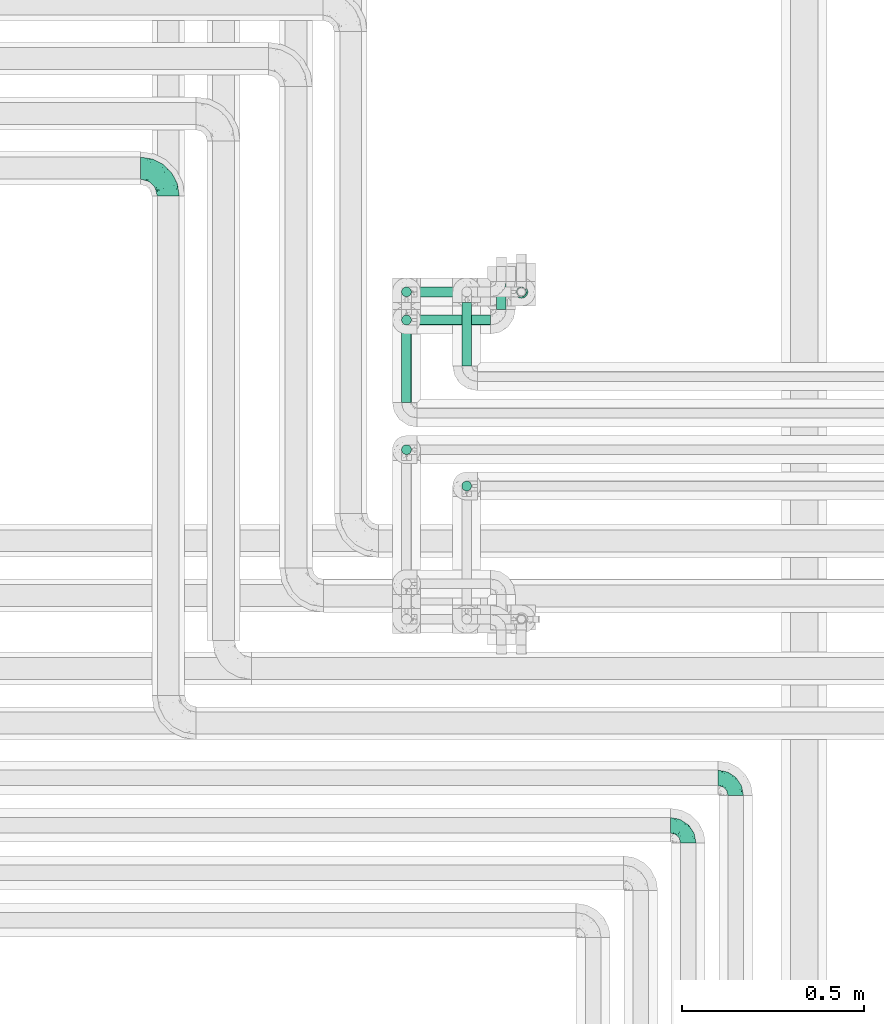
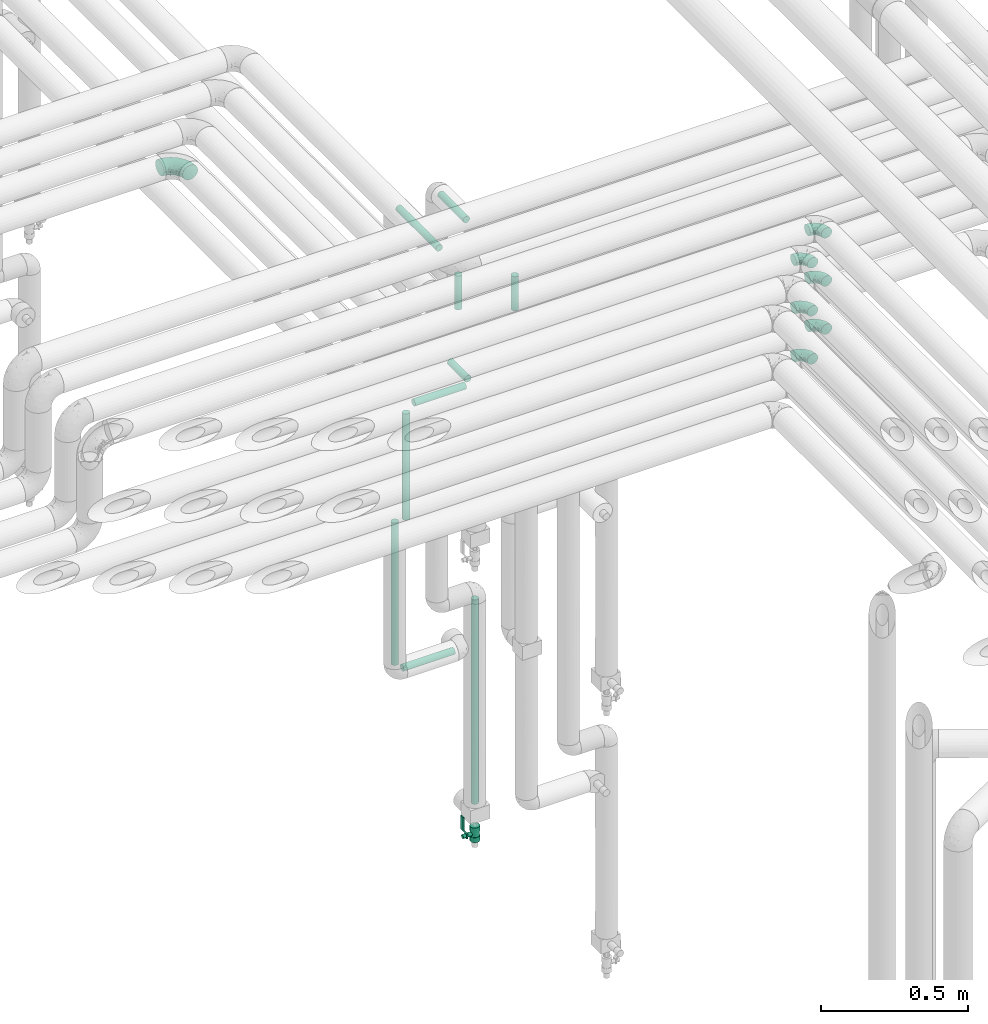
# One storey, part 635 of 824: 10 flow segments, 7 flow fittings, 1 flow controller.
"""IFC2X3 building model written with IfcOpenShell, lengths in millimetres."""

from ifc_helpers import new_model, entity, si_unit, converted_unit, derived_unit, direction, frame, origin, origin_2d_with_axis, place, context, subcontext, project, spatial, polyline, circle, outline, extrude, faceted_brep, source, transform, mapped, material, material_list, type_object, type_shapes, element, save


model = new_model("IFC2X3")

# Units and contexts
model_context = context("Model", 3, precision=0.01, world=origin(), true_north=direction((6.12303176911189e-17, 1.0)))
body_context = subcontext(model_context, "Body", "Model", "MODEL_VIEW")
ifc_project = project(units=[si_unit("LENGTHUNIT", "METRE", prefix="MILLI"), si_unit("AREAUNIT", "SQUARE_METRE"), si_unit("VOLUMEUNIT", "CUBIC_METRE"), converted_unit("PLANEANGLEUNIT", "DEGREE", entity("IfcRatioMeasure", 0.0174532925199433), si_unit("PLANEANGLEUNIT", "RADIAN"), dimensions=[0, 0, 0, 0, 0, 0, 0]), si_unit("MASSUNIT", "GRAM", prefix="KILO"), derived_unit("MASSDENSITYUNIT", [(si_unit("MASSUNIT", "GRAM", prefix="KILO"), 1), (si_unit("LENGTHUNIT", "METRE"), -3)]), derived_unit("MOMENTOFINERTIAUNIT", [(si_unit("LENGTHUNIT", "METRE"), 4)]), si_unit("TIMEUNIT", "SECOND"), si_unit("FREQUENCYUNIT", "HERTZ"), si_unit("THERMODYNAMICTEMPERATUREUNIT", "DEGREE_CELSIUS"), derived_unit("THERMALTRANSMITTANCEUNIT", [(si_unit("MASSUNIT", "GRAM", prefix="KILO"), 1), (si_unit("THERMODYNAMICTEMPERATUREUNIT", "KELVIN"), -1), (si_unit("TIMEUNIT", "SECOND"), -3)]), derived_unit("VOLUMETRICFLOWRATEUNIT", [(si_unit("LENGTHUNIT", "METRE"), 3), (si_unit("TIMEUNIT", "SECOND"), -1)]), derived_unit("MASSFLOWRATEUNIT", [(si_unit("MASSUNIT", "GRAM", prefix="KILO"), 1), (si_unit("TIMEUNIT", "SECOND"), -1)]), derived_unit("ROTATIONALFREQUENCYUNIT", [(si_unit("TIMEUNIT", "SECOND"), -1)]), si_unit("ELECTRICCURRENTUNIT", "AMPERE"), si_unit("ELECTRICVOLTAGEUNIT", "VOLT"), si_unit("POWERUNIT", "WATT"), si_unit("FORCEUNIT", "NEWTON", prefix="KILO"), si_unit("ILLUMINANCEUNIT", "LUX"), si_unit("LUMINOUSFLUXUNIT", "LUMEN"), si_unit("LUMINOUSINTENSITYUNIT", "CANDELA"), derived_unit("USERDEFINED", [(si_unit("MASSUNIT", "GRAM", prefix="KILO"), -1), (si_unit("LENGTHUNIT", "METRE"), -2), (si_unit("TIMEUNIT", "SECOND"), 3), (si_unit("LUMINOUSFLUXUNIT", "LUMEN"), 1)]), derived_unit("LINEARVELOCITYUNIT", [(si_unit("LENGTHUNIT", "METRE"), 1), (si_unit("TIMEUNIT", "SECOND"), -1)]), si_unit("PRESSUREUNIT", "PASCAL"), derived_unit("USERDEFINED", [(si_unit("LENGTHUNIT", "METRE"), -2), (si_unit("MASSUNIT", "GRAM", prefix="KILO"), 1), (si_unit("TIMEUNIT", "SECOND"), -2)]), derived_unit("LINEARFORCEUNIT", [(si_unit("MASSUNIT", "GRAM", prefix="KILO"), 1), (si_unit("LENGTHUNIT", "METRE"), 1), (si_unit("TIMEUNIT", "SECOND"), -2), (si_unit("LENGTHUNIT", "METRE"), -1)]), derived_unit("PLANARFORCEUNIT", [(si_unit("MASSUNIT", "GRAM", prefix="KILO"), 1), (si_unit("LENGTHUNIT", "METRE"), 1), (si_unit("TIMEUNIT", "SECOND"), -2), (si_unit("LENGTHUNIT", "METRE"), -2)])], contexts=[model_context])

# Site, building, storey
site_placement = place(None, origin())
site = spatial("IfcSite", under=ifc_project, at=site_placement, CompositionType="ELEMENT")
building_placement = place(site_placement, origin())
building = spatial("IfcBuilding", under=site, at=building_placement, CompositionType="ELEMENT")
storey_placement = place(building_placement, frame((0.0, 0.0, 28200.0)))
storey = spatial("IfcBuildingStorey", under=building, at=storey_placement, CompositionType="ELEMENT", Elevation=28200.0)

# Flow segments
pipe_segment_type = type_object("IfcPipeSegmentType", PredefinedType="NOTDEFINED")
flow_segment_1_placement = place(storey_placement, frame((34812.85, 15519.1, 2985.0)))
element("IfcFlowSegment", 1, at=flow_segment_1_placement, inside=storey, type_object=pipe_segment_type, context=body_context, shape_type="SweptSolid", body=[
    extrude(circle(Radius=13.4, at=origin_2d_with_axis()), frame((15.0, 0.0, 15.0), z_axis=(0.0, 1.0, 0.0), x_axis=(1.0, 0.0, 0.0)), (0.0, 0.0, 1.0), 273.847303750792),
])
flow_segment_2_placement = place(storey_placement, frame((34977.89, 15619.14, 2985.0)))
element("IfcFlowSegment", 2, at=flow_segment_2_placement, inside=storey, type_object=pipe_segment_type, context=body_context, shape_type="SweptSolid", body=[
    extrude(circle(Radius=13.4, at=origin_2d_with_axis()), frame((15.0, 0.0, 15.0), z_axis=(0.0, 1.0, 0.0), x_axis=(1.0, 0.0, 0.0)), (0.0, 0.0, 1.0), 173.806350271803),
])
flow_segment_3_placement = place(storey_placement, frame((35127.89, 15807.05, 401.0)))
element("IfcFlowSegment", 3, at=flow_segment_3_placement, inside=storey, type_object=pipe_segment_type, context=body_context, shape_type="SweptSolid", body=[
    extrude(circle(Radius=13.4, at=origin_2d_with_axis()), frame((15.0, 15.0, 0.0)), (0.0, 0.0, 1.0), 849.899999999534),
])
flow_segment_4_placement = place(storey_placement, frame((34812.85, 15807.05, 1089.1)))
element("IfcFlowSegment", 4, at=flow_segment_4_placement, inside=storey, type_object=pipe_segment_type, context=body_context, shape_type="SweptSolid", body=[
    extrude(circle(Radius=13.4, at=origin_2d_with_axis()), frame((15.0, 15.0, 0.0)), (0.0, 0.0, 1.0), 591.900000000008),
])
flow_segment_5_placement = place(storey_placement, frame((34856.95, 15807.05, 1045.0)))
element("IfcFlowSegment", 5, at=flow_segment_5_placement, inside=storey, type_object=pipe_segment_type, context=body_context, shape_type="SweptSolid", body=[
    extrude(circle(Radius=13.4, at=origin_2d_with_axis()), frame((0.0, 15.0, 15.0), z_axis=(1.0, 0.0, 0.0), x_axis=(0.0, -1.0, 0.0)), (0.0, 0.0, 1.0), 201.799999999997),
])
flow_segment_6_placement = place(storey_placement, frame((34856.95, 15730.06, 2195.0)))
element("IfcFlowSegment", 6, at=flow_segment_6_placement, inside=storey, type_object=pipe_segment_type, context=body_context, shape_type="SweptSolid", body=[
    extrude(circle(Radius=13.4, at=origin_2d_with_axis()), frame((0.0, 15.0, 15.0), z_axis=(1.0, 0.0, 0.0), x_axis=(0.0, 1.0, 0.0)), (0.0, 0.0, 1.0), 201.799999999997),
])
flow_segment_7_placement = place(storey_placement, frame((35072.85, 15774.15, 2195.0)))
element("IfcFlowSegment", 7, at=flow_segment_7_placement, inside=storey, type_object=pipe_segment_type, context=body_context, shape_type="SweptSolid", body=[
    extrude(circle(Radius=13.4, at=origin_2d_with_axis()), frame((15.0, 0.0, 15.0), z_axis=(0.0, 1.0, 0.0), x_axis=(-1.0, 0.0, 0.0)), (0.0, 0.0, 1.0), 117.895089895177),
])
flow_segment_8_placement = place(storey_placement, frame((34812.85, 15730.06, 1739.1)))
element("IfcFlowSegment", 8, at=flow_segment_8_placement, inside=storey, type_object=pipe_segment_type, context=body_context, shape_type="SweptSolid", body=[
    extrude(circle(Radius=13.4, at=origin_2d_with_axis()), frame((15.0, 15.0, 0.0)), (0.0, 0.0, 1.0), 441.800000000021),
])
flow_segment_9_placement = place(storey_placement, frame((34977.89, 15275.0, 2829.1)))
element("IfcFlowSegment", 9, at=flow_segment_9_placement, inside=storey, type_object=pipe_segment_type, context=body_context, shape_type="SweptSolid", body=[
    extrude(circle(Radius=13.4, at=origin_2d_with_axis()), frame((15.0, 15.0, 0.0), z_axis=(0.0, 0.0, 1.0), x_axis=(-1.0, 0.0, 0.0)), (0.0, 0.0, 1.0), 141.800000000046),
])
flow_segment_10_placement = place(storey_placement, frame((34812.85, 15374.6, 2829.1)))
element("IfcFlowSegment", 10, at=flow_segment_10_placement, inside=storey, type_object=pipe_segment_type, context=body_context, shape_type="SweptSolid", body=[
    extrude(circle(Radius=13.4, at=origin_2d_with_axis()), frame((15.0, 15.0, 0.0), z_axis=(0.0, 0.0, 1.0), x_axis=(-1.0, 0.0, 0.0)), (0.0, 0.0, 1.0), 141.800000000024),
])

# Flow controller
ifc_material = material()
ifc_material_list = material_list([ifc_material, ifc_material, ifc_material, ifc_material, ifc_material])
valve_type = type_object("IfcValveType", PredefinedType="NOTDEFINED", material=ifc_material_list)
shared_shape_1 = source(origin(), body_context, "Body", "SweptSolid", [
    extrude(circle(Radius=17.5, at=origin_2d_with_axis()), frame((-30.5, 0.0, 0.0), z_axis=(1.0, 0.0, 0.0), x_axis=(0.0, 1.0, 0.0)), (0.0, 0.0, 1.0), 20.3333333333333),
    extrude(circle(Radius=16.0, at=origin_2d_with_axis()), frame((-10.17, 0.0, 0.0), z_axis=(1.0, 0.0, 0.0), x_axis=(0.0, 1.0, 0.0)), (0.0, 0.0, 1.0), 20.3333333333333),
    extrude(circle(Radius=17.5, at=origin_2d_with_axis()), frame((10.17, 0.0, 0.0), z_axis=(1.0, 0.0, 0.0), x_axis=(0.0, 1.0, 0.0)), (0.0, 0.0, 1.0), 20.3333333333333),
    extrude(outline(polyline([(-38.75, -5.0), (-38.75, -10.0), (-17.92, -10.0), (2.08, 5.0), (56.25, 5.0), (56.25, 10.0), (0.42, 10.0), (-19.58, -5.0), (-38.75, -5.0)])), frame((28.75, -8.75, 41.5), z_axis=(0.0, -1.0, 0.0), x_axis=(1.0, 0.0, 0.0)), (0.0, 0.0, -1.0), 17.5),
    extrude(circle(Radius=8.0, at=origin_2d_with_axis()), origin(), (0.0, 0.0, 1.0), 49.0),
])
type_shapes(valve_type, [shared_shape_1])
flow_controller_placement = place(storey_placement, frame((35142.88, 15822.05, 274.5), z_axis=(-1.0, 0.0, 0.0), x_axis=(0.0, 0.0, 1.0)))
element("IfcFlowController", 11, at=flow_controller_placement, inside=storey, type_object=valve_type, material=ifc_material, context=body_context, shape_type="MappedRepresentation", body=[
    mapped(shared_shape_1, transform((0.0, 0.0, 0.0), scale=1.0)),
])

# Flow fittings
pipe_fitting_type_1 = type_object("IfcPipeFittingType", PredefinedType="NOTDEFINED", material=ifc_material)
shared_shape_2 = source(origin(), body_context, "Body", "Brep", [
    faceted_brep([(-48.0, 10.6, -18.36), (-48.0, 5.49, -20.48), (-48.0, 0.0, -21.2), (-48.0, -5.49, -20.48), (-48.0, -10.6, -18.36), (-48.0, -14.99, -14.99), (-48.0, -18.36, -10.6), (-48.0, -20.48, -5.49), (-48.0, -21.2, 0.0), (-48.0, -20.48, 5.49), (-48.0, -18.36, 10.6), (-48.0, -14.99, 14.99), (-48.0, -10.6, 18.36), (-48.0, -5.49, 20.48), (-48.0, 0.0, 21.2), (-48.0, 5.49, 20.48), (-48.0, 10.6, 18.36), (-48.0, 14.99, 14.99), (-48.0, 18.36, 10.6), (-48.0, 20.48, 5.49), (-48.0, 21.2, 0.0), (-48.0, 20.48, -5.49), (-48.0, 18.36, -10.6), (-48.0, 14.99, -14.99), (0.0, 48.0, -21.2), (-5.49, 48.0, -20.48), (-10.6, 48.0, -18.36), (-14.99, 48.0, -14.99), (-18.36, 48.0, -10.6), (-20.48, 48.0, -5.49), (-21.2, 48.0, 0.0), (-20.48, 48.0, 5.49), (-18.36, 48.0, 10.6), (-14.99, 48.0, 14.99), (-10.6, 48.0, 18.36), (-5.49, 48.0, 20.48), (0.0, 48.0, 21.2), (5.49, 48.0, 20.48), (10.6, 48.0, 18.36), (14.99, 48.0, 14.99), (18.36, 48.0, 10.6), (20.48, 48.0, 5.49), (21.2, 48.0, 0.0), (20.48, 48.0, -5.49), (18.36, 48.0, -10.6), (14.99, 48.0, -14.99), (10.6, 48.0, -18.36), (5.49, 48.0, -20.48), (-35.25, -16.22, 12.01), (-34.76, -18.57, 0.0), (-20.87, -12.37, 10.9), (-31.49, -11.78, 15.9), (-37.0, -2.58, 20.86), (-33.89, 3.62, 21.15), (-31.81, -18.14, 6.76), (-5.78, 5.78, 17.67), (-19.42, -4.1, 17.86), (-9.6, -3.39, 13.73), (-35.44, -7.73, 19.13), (11.78, 31.49, 15.9), (-5.93, -5.46, 6.95), (-18.45, -13.78, 5.46), (-10.29, -8.43, 0.0), (-24.6, 0.55, 20.62), (-37.28, 17.94, 13.81), (-33.38, 22.85, 9.59), (-41.46, 20.06, 8.75), (-29.51, 20.45, 15.16), (-15.04, 10.79, 21.13), (-7.08, 16.98, 20.93), (-8.39, 23.51, 21.15), (-40.86, 13.03, 17.26), (-8.05, 41.26, 19.83), (-3.21, 35.97, 21.14), (8.53, 19.66, 14.74), (4.1, 19.42, 17.86), (-37.72, 22.66, 4.78), (-37.07, 8.58, 19.98), (-13.0, 5.43, 19.97), (-3.78, 13.93, 19.7), (3.02, 8.69, 13.43), (-2.27, -0.05, 10.65), (6.22, 6.99, 7.09), (-22.25, 34.6, 9.45), (18.14, 31.81, 6.76), (16.22, 35.25, 12.01), (12.37, 20.87, 10.9), (7.73, 35.44, 19.13), (-21.52, -15.93, 0.0), (2.58, 37.0, 20.86), (18.57, 34.76, 0.0), (13.78, 18.45, 5.46), (15.93, 21.52, 0.0), (-20.03, -8.54, 14.9), (-28.6, 28.6, 5.16), (-24.79, 34.6, 0.0), (-34.6, 24.79, 0.0), (-22.81, 37.41, 4.68), (-23.36, 26.33, 14.79), (-13.68, 37.05, 17.49), (-17.72, 38.12, 13.73), (-26.25, 27.3, 11.24), (-9.71, 32.34, 20.14), (-17.26, 25.6, 18.71), (-26.33, 9.99, 20.77), (-24.06, 6.05, 21.2), (-25.02, 15.46, 19.56), (-24.3, 20.72, 17.57), (-31.95, 15.23, 17.8), (-13.53, 24.7, 20.21), (-17.6, 17.6, 20.6), (-0.55, 24.6, 20.62), (-11.41, -7.48, 10.43), (0.93, -0.93, 0.0), (8.43, 10.29, 0.0), (-11.41, -7.48, -10.43), (-20.1, -8.84, -14.66), (-9.6, -3.39, -13.73), (7.73, 35.44, -19.13), (4.1, 19.42, -17.86), (-0.55, 24.6, -20.62), (-38.12, 17.72, -13.73), (-37.05, 13.68, -17.49), (-32.34, 9.71, -20.14), (-41.26, 8.05, -19.83), (-37.41, 22.81, -4.68), (-23.51, 8.39, -21.15), (-35.97, 3.21, -21.14), (-28.6, 28.6, -5.16), (-31.81, -18.14, -6.76), (-18.45, -13.78, -5.46), (-25.6, 17.26, -18.71), (-19.42, -4.1, -17.86), (-17.94, 37.28, -13.81), (-22.85, 33.38, -9.59), (-20.06, 41.46, -8.75), (-31.49, -11.78, -15.9), (-35.25, -16.22, -12.01), (8.53, 19.66, -14.74), (11.78, 31.49, -15.9), (-9.99, 26.33, -20.77), (-6.05, 24.06, -21.2), (-10.79, 15.04, -21.13), (-37.0, -2.58, -20.86), (-16.98, 7.08, -20.93), (-5.43, 13.0, -19.97), (-13.93, 3.78, -19.7), (-20.87, -12.37, -10.9), (-26.33, 23.36, -14.79), (-22.66, 37.72, -4.78), (13.78, 18.45, -5.46), (18.14, 31.81, -6.76), (-15.46, 25.02, -19.56), (-20.72, 24.3, -17.57), (16.22, 35.25, -12.01), (-13.03, 40.86, -17.26), (-8.58, 37.07, -19.98), (2.58, 37.0, -20.86), (-3.62, 33.89, -21.15), (-34.6, 22.25, -9.45), (6.22, 6.99, -7.09), (-20.45, 29.51, -15.16), (-35.44, -7.73, -19.13), (12.37, 20.87, -10.9), (-27.3, 26.25, -11.24), (-15.23, 31.95, -17.8), (-24.7, 13.53, -20.21), (-24.6, 0.55, -20.62), (-5.78, 5.78, -17.67), (-17.6, 17.6, -20.6), (3.02, 8.69, -13.43), (-5.93, -5.46, -6.95), (-2.27, -0.05, -10.65)], [[[0, 1, 2, 3, 4, 5, 6, 7, 8, 9, 10, 11, 12, 13, 14, 15, 16, 17, 18, 19, 20, 21, 22, 23]], [[24, 25, 26, 27, 28, 29, 30, 31, 32, 33, 34, 35, 36, 37, 38, 39, 40, 41, 42, 43, 44, 45, 46, 47]], [[10, 48, 11]], [[9, 8, 49]], [[48, 50, 51]], [[14, 52, 53]], [[10, 54, 48]], [[9, 54, 10]], [[55, 56, 57]], [[51, 12, 11]], [[51, 58, 12]], [[59, 39, 38]], [[60, 61, 62]], [[58, 56, 63]], [[64, 65, 66]], [[67, 65, 64]], [[68, 69, 70]], [[16, 71, 17]], [[13, 52, 14]], [[35, 72, 73]], [[14, 53, 15]], [[17, 64, 18]], [[74, 59, 75]], [[20, 19, 76]], [[66, 19, 18]], [[77, 15, 53]], [[15, 77, 16]], [[69, 78, 79]], [[80, 81, 82]], [[32, 31, 83]], [[84, 85, 86]], [[59, 87, 75]], [[61, 54, 88]], [[36, 89, 37]], [[84, 41, 40]], [[36, 35, 73]], [[90, 41, 84]], [[40, 39, 85]], [[12, 58, 13]], [[85, 84, 40]], [[91, 84, 86]], [[84, 92, 90]], [[87, 38, 37]], [[93, 56, 51]], [[65, 94, 76]], [[94, 95, 96]], [[84, 91, 92]], [[95, 97, 30]], [[98, 99, 100]], [[76, 94, 96]], [[101, 98, 83]], [[100, 99, 33]], [[102, 70, 73]], [[103, 102, 99]], [[94, 97, 95]], [[72, 99, 102]], [[72, 35, 34]], [[34, 33, 99]], [[9, 49, 54]], [[87, 59, 38]], [[104, 105, 68]], [[106, 103, 107]], [[106, 77, 104]], [[71, 64, 17]], [[108, 107, 67]], [[33, 32, 100]], [[109, 103, 110]], [[102, 109, 70]], [[89, 73, 111]], [[50, 48, 54]], [[51, 11, 48]], [[56, 58, 51]], [[88, 54, 49]], [[52, 58, 63]], [[50, 112, 93]], [[56, 55, 78]], [[39, 59, 85]], [[86, 85, 59]], [[89, 87, 37]], [[42, 41, 90]], [[111, 79, 75]], [[111, 75, 87]], [[75, 55, 80]], [[104, 77, 53]], [[71, 77, 108]], [[32, 83, 100]], [[98, 100, 83]], [[99, 98, 103]], [[106, 107, 108]], [[68, 70, 110]], [[111, 73, 70]], [[68, 110, 104]], [[68, 63, 78]], [[57, 93, 112]], [[80, 55, 57]], [[61, 50, 54]], [[80, 82, 86]], [[81, 57, 112]], [[74, 86, 59]], [[60, 113, 82]], [[82, 114, 91]], [[101, 94, 65]], [[97, 94, 83]], [[73, 89, 36]], [[87, 89, 111]], [[58, 52, 13]], [[53, 52, 63]], [[104, 53, 105]], [[106, 104, 110]], [[20, 76, 96]], [[76, 19, 66]], [[103, 106, 110]], [[77, 106, 108]], [[103, 98, 107]], [[67, 107, 98]], [[67, 98, 101]], [[108, 67, 64]], [[53, 63, 105]], [[63, 68, 105]], [[83, 31, 97]], [[30, 97, 31]], [[62, 113, 60]], [[112, 61, 60]], [[61, 88, 62]], [[86, 82, 91]], [[56, 78, 63]], [[114, 82, 113]], [[114, 92, 91]], [[79, 78, 55]], [[75, 79, 55]], [[69, 79, 111]], [[70, 69, 111]], [[78, 69, 68]], [[77, 71, 16]], [[64, 71, 108]], [[64, 66, 18]], [[76, 66, 65]], [[99, 72, 34]], [[73, 72, 102]], [[94, 101, 83]], [[67, 101, 65]], [[75, 80, 74]], [[80, 86, 74]], [[70, 109, 110]], [[102, 103, 109]], [[50, 93, 51]], [[57, 56, 93]], [[61, 112, 50]], [[81, 112, 60]], [[82, 81, 60]], [[80, 57, 81]], [[115, 116, 117]], [[118, 119, 120]], [[121, 122, 23]], [[123, 124, 122]], [[96, 125, 20]], [[123, 126, 127]], [[128, 96, 95]], [[129, 130, 88]], [[123, 122, 131]], [[116, 132, 117]], [[133, 134, 135]], [[0, 124, 1]], [[5, 136, 137]], [[138, 119, 139]], [[129, 88, 49]], [[140, 141, 142]], [[6, 5, 137]], [[46, 118, 47]], [[143, 3, 2]], [[144, 145, 146]], [[6, 129, 7]], [[129, 137, 147]], [[127, 2, 1]], [[148, 122, 121]], [[128, 125, 96]], [[134, 128, 149]], [[95, 149, 128]], [[150, 151, 92]], [[30, 29, 149]], [[152, 131, 153]], [[27, 133, 28]], [[154, 45, 44]], [[136, 5, 4]], [[27, 26, 155]], [[156, 26, 25]], [[24, 157, 158]], [[24, 47, 157]], [[22, 21, 159]], [[160, 150, 114]], [[134, 133, 161]], [[142, 144, 126]], [[46, 139, 118]], [[162, 136, 4]], [[156, 25, 158]], [[1, 124, 127]], [[115, 147, 116]], [[45, 154, 139]], [[139, 46, 45]], [[154, 163, 139]], [[162, 4, 3]], [[42, 90, 43]], [[130, 129, 147]], [[49, 7, 129]], [[43, 151, 44]], [[0, 23, 122]], [[24, 158, 25]], [[136, 162, 132]], [[135, 29, 28]], [[43, 90, 151]], [[164, 148, 159]], [[152, 156, 140]], [[155, 133, 27]], [[165, 153, 161]], [[23, 22, 121]], [[123, 131, 166]], [[123, 166, 126]], [[143, 127, 167]], [[147, 137, 136]], [[8, 7, 49]], [[129, 6, 137]], [[143, 162, 3]], [[167, 146, 132]], [[167, 132, 162]], [[132, 168, 117]], [[44, 151, 154]], [[92, 151, 90]], [[163, 154, 151]], [[119, 118, 139]], [[157, 118, 120]], [[138, 139, 163]], [[119, 168, 145]], [[140, 156, 158]], [[155, 156, 165]], [[22, 159, 121]], [[148, 121, 159]], [[122, 148, 131]], [[152, 153, 165]], [[142, 126, 169]], [[167, 127, 126]], [[142, 169, 140]], [[142, 120, 145]], [[168, 170, 117]], [[160, 171, 172]], [[115, 172, 171]], [[171, 62, 130]], [[119, 170, 168]], [[170, 163, 160]], [[150, 163, 151]], [[113, 171, 160]], [[164, 128, 134]], [[125, 128, 159]], [[127, 143, 2]], [[162, 143, 167]], [[118, 157, 47]], [[158, 157, 120]], [[140, 158, 141]], [[152, 140, 169]], [[30, 149, 95]], [[149, 29, 135]], [[131, 152, 169]], [[156, 152, 165]], [[131, 148, 153]], [[161, 153, 148]], [[161, 148, 164]], [[165, 161, 133]], [[158, 120, 141]], [[120, 142, 141]], [[159, 21, 125]], [[20, 125, 21]], [[115, 130, 147]], [[114, 113, 160]], [[62, 171, 113]], [[62, 88, 130]], [[160, 163, 150]], [[150, 92, 114]], [[119, 145, 120]], [[146, 145, 168]], [[132, 146, 168]], [[144, 146, 167]], [[126, 144, 167]], [[145, 144, 142]], [[156, 155, 26]], [[133, 155, 165]], [[133, 135, 28]], [[149, 135, 134]], [[122, 124, 0]], [[127, 124, 123]], [[128, 164, 159]], [[161, 164, 134]], [[163, 170, 138]], [[170, 119, 138]], [[131, 169, 166]], [[126, 166, 169]], [[147, 136, 116]], [[132, 116, 136]], [[172, 115, 117]], [[130, 115, 171]], [[117, 170, 172]], [[160, 172, 170]]]),
])
type_shapes(pipe_fitting_type_1, [shared_shape_2])
for number, where, z_axis, x_axis in (
    (12, (35730.03, 14490.0, 3000.0), (0.0, 0.0, 1.0), (0.0, 1.0, 0.0)),
    (13, (35600.09, 14360.0, 3000.0), (0.0, 0.0, 1.0), (0.0, 1.0, 0.0)),
    (14, (35600.09, 14360.0, 3200.0), (0.0, 0.0, 1.0), (0.0, 1.0, 0.0)),
    (15, (35730.03, 14490.0, 3200.0), (0.0, 0.0, 1.0), (0.0, 1.0, 0.0)),
    (16, (35600.09, 14360.0, 3400.0), (0.0, 0.0, 1.0), (0.0, 1.0, 0.0)),
    (17, (35730.03, 14490.0, 3400.0), (0.0, 0.0, 1.0), (0.0, 1.0, 0.0)),
):
    element("IfcFlowFitting", number, at=place(storey_placement, frame(where, z_axis=z_axis, x_axis=x_axis)), inside=storey, type_object=pipe_fitting_type_1, material=ifc_material, context=body_context, shape_type="MappedRepresentation", body=[
        mapped(shared_shape_2, transform((0.0, 0.0, 0.0), scale=1.0)),
    ])
pipe_fitting_type_2 = type_object("IfcPipeFittingType", PredefinedType="NOTDEFINED", material=ifc_material)
shared_shape_3 = source(origin(), body_context, "Body", "Brep", [
    faceted_brep([(-76.0, 15.07, -26.11), (-76.0, 7.8, -29.12), (-76.0, 0.0, -30.15), (-76.0, -7.8, -29.12), (-76.0, -15.08, -26.11), (-76.0, -21.32, -21.32), (-76.0, -26.11, -15.08), (-76.0, -29.12, -7.8), (-76.0, -30.15, 0.0), (-76.0, -29.12, 7.8), (-76.0, -26.11, 15.07), (-76.0, -21.32, 21.32), (-76.0, -15.08, 26.11), (-76.0, -7.8, 29.12), (-76.0, 0.0, 30.15), (-76.0, 7.8, 29.12), (-76.0, 15.07, 26.11), (-76.0, 21.32, 21.32), (-76.0, 26.11, 15.07), (-76.0, 29.12, 7.8), (-76.0, 30.15, 0.0), (-76.0, 29.12, -7.8), (-76.0, 26.11, -15.08), (-76.0, 21.32, -21.32), (0.0, 76.0, -30.15), (-7.8, 76.0, -29.12), (-15.07, 76.0, -26.11), (-21.32, 76.0, -21.32), (-26.11, 76.0, -15.08), (-29.12, 76.0, -7.8), (-30.15, 76.0, 0.0), (-29.12, 76.0, 7.8), (-26.11, 76.0, 15.07), (-21.32, 76.0, 21.32), (-15.07, 76.0, 26.11), (-7.8, 76.0, 29.12), (0.0, 76.0, 30.15), (7.8, 76.0, 29.12), (15.08, 76.0, 26.11), (21.32, 76.0, 21.32), (26.11, 76.0, 15.07), (29.12, 76.0, 7.8), (30.15, 76.0, 0.0), (29.12, 76.0, -7.8), (26.11, 76.0, -15.08), (21.32, 76.0, -21.32), (15.08, 76.0, -26.11), (7.8, 76.0, -29.12), (10.79, 31.43, 21.07), (4.32, 31.7, 25.72), (1.65, 15.19, 19.92), (-61.17, -27.8, 0.0), (-51.1, -25.49, 9.84), (-56.14, -10.61, 27.27), (-31.7, -4.32, 25.72), (-39.75, 1.72, 29.41), (-43.2, -24.95, 0.0), (-1.86, 1.86, 0.0), (4.49, 7.65, 5.78), (-7.82, -4.61, 5.83), (-56.21, -22.79, 17.21), (-58.98, -3.38, 29.7), (-53.96, 5.6, 30.07), (-10.86, 10.86, 25.48), (-17.2, -2.6, 20.44), (-49.15, -16.01, 22.7), (-22.18, -14.24, 7.99), (-28.4, -17.42, 0.0), (-13.61, -9.88, 0.0), (-39.0, 23.48, 27.76), (-58.76, 12.54, 28.36), (-41.61, 15.41, 29.48), (16.01, 49.15, 22.7), (-58.55, 25.93, 19.53), (-51.53, 33.5, 13.51), (-64.92, 28.76, 12.4), (-7.48, 23.14, 28.25), (-1.72, 39.75, 29.41), (-12.04, 27.88, 29.88), (-63.91, 18.81, 24.52), (-11.63, 65.16, 28.18), (-4.97, 57.02, 30.05), (9.88, 13.61, 0.0), (-62.5, 31.74, 5.02), (-45.17, 30.98, 21.2), (-21.78, 9.76, 28.58), (10.61, 56.14, 27.27), (-32.09, 54.42, 13.26), (22.79, 56.21, 17.21), (15.38, 31.17, 15.63), (25.49, 51.1, 9.84), (21.84, 36.35, 5.92), (24.95, 43.2, 0.0), (3.38, 58.98, 29.7), (-31.17, -15.38, 15.63), (-39.39, 41.78, 15.45), (-34.56, 41.13, 20.79), (-39.81, -23.25, 5.49), (27.8, 61.17, 0.0), (-31.74, 62.5, 5.02), (-53.07, 36.29, 0.0), (-42.95, 42.95, 7.29), (-36.29, 53.07, 0.0), (-19.83, 58.51, 24.79), (-25.48, 60.2, 19.41), (-14.53, 50.96, 28.57), (-13.31, 37.09, 30.07), (-26.16, 40.06, 26.4), (-32.43, -10.35, 21.9), (17.42, 28.4, 0.0), (14.24, 22.18, 7.99), (-38.67, 9.72, 30.15), (-24.66, 17.36, 30.09), (-37.08, 31.49, 24.99), (-49.27, 22.83, 25.24), (-20.8, 38.81, 28.63), (-27.58, 27.58, 29.2), (-36.07, -20.23, 10.71), (-15.19, -6.16, 14.9), (6.6, 15.4, 14.49), (-2.51, 2.51, 11.35), (-65.16, 11.63, -28.18), (-49.15, -16.01, -22.7), (-57.02, 4.97, -30.05), (-25.93, 58.55, -19.53), (-33.5, 51.53, -13.51), (-28.76, 64.92, -12.4), (-60.2, 25.48, -19.41), (-58.51, 19.83, -24.79), (4.61, 7.82, -5.83), (-7.65, -4.49, -5.78), (-2.51, 2.51, -11.35), (-62.5, 31.74, -5.02), (-50.96, 14.53, -28.57), (-37.09, 13.31, -30.07), (-42.95, 42.95, -7.29), (25.49, 51.1, -9.84), (22.79, 56.21, -17.21), (-40.06, 26.16, -26.4), (3.38, 58.98, -29.7), (-5.6, 53.96, -30.07), (-27.88, 12.04, -29.88), (-9.76, 21.78, -28.58), (-23.14, 7.48, -28.25), (-51.1, -25.49, -9.84), (15.38, 31.17, -15.63), (16.01, 49.15, -22.7), (-23.48, 39.0, -27.76), (-12.54, 58.76, -28.36), (-15.41, 41.61, -29.48), (-56.21, -22.79, -17.21), (-9.72, 38.67, -30.15), (-17.36, 24.66, -30.09), (-22.18, -14.24, -7.99), (-41.13, 34.56, -20.79), (-31.74, 62.5, -5.02), (-58.98, -3.38, -29.7), (-31.17, -15.38, -15.63), (-56.14, -10.61, -27.27), (14.24, 22.18, -7.99), (23.25, 39.81, -5.49), (-31.49, 37.08, -24.99), (-15.19, -6.16, -14.9), (1.65, 15.19, -19.92), (-18.81, 63.91, -24.52), (-32.59, -11.62, -20.84), (-31.7, -4.32, -25.72), (-17.2, -2.6, -20.44), (-39.75, 1.72, -29.41), (-54.42, 32.09, -13.26), (-30.98, 45.17, -21.2), (10.61, 56.14, -27.27), (10.23, 31.31, -21.52), (4.32, 31.7, -25.72), (-41.78, 39.39, -15.45), (-1.72, 39.75, -29.41), (-36.35, -21.84, -5.92), (-22.83, 49.27, -25.24), (-38.81, 20.8, -28.63), (-27.58, 27.58, -29.2), (-10.86, 10.86, -25.48), (20.23, 36.07, -10.71), (6.6, 15.4, -14.49)], [[[0, 1, 2, 3, 4, 5, 6, 7, 8, 9, 10, 11, 12, 13, 14, 15, 16, 17, 18, 19, 20, 21, 22, 23]], [[24, 25, 26, 27, 28, 29, 30, 31, 32, 33, 34, 35, 36, 37, 38, 39, 40, 41, 42, 43, 44, 45, 46, 47]], [[48, 49, 50]], [[51, 52, 9]], [[53, 54, 55]], [[9, 52, 10]], [[56, 52, 51]], [[57, 58, 59]], [[11, 10, 60]], [[14, 61, 62]], [[63, 54, 64]], [[65, 12, 11]], [[65, 53, 12]], [[66, 67, 68]], [[69, 70, 71]], [[72, 39, 38]], [[73, 74, 75]], [[15, 70, 16]], [[76, 77, 78]], [[16, 79, 17]], [[13, 61, 14]], [[35, 80, 81]], [[14, 62, 15]], [[17, 73, 18]], [[57, 82, 58]], [[20, 19, 83]], [[75, 19, 18]], [[70, 15, 62]], [[73, 84, 74]], [[78, 85, 76]], [[38, 86, 72]], [[32, 31, 87]], [[88, 89, 90]], [[91, 92, 90]], [[72, 86, 49]], [[36, 93, 37]], [[75, 83, 19]], [[36, 35, 81]], [[60, 94, 65]], [[40, 90, 41]], [[95, 96, 87]], [[88, 90, 40]], [[66, 97, 67]], [[90, 98, 41]], [[40, 39, 88]], [[99, 31, 30]], [[20, 83, 100]], [[101, 102, 100]], [[52, 60, 10]], [[102, 99, 30]], [[96, 103, 104]], [[83, 101, 100]], [[12, 53, 13]], [[104, 103, 33]], [[105, 106, 81]], [[107, 105, 103]], [[64, 54, 108]], [[80, 103, 105]], [[80, 35, 34]], [[34, 33, 103]], [[86, 38, 37]], [[109, 110, 82]], [[71, 111, 112]], [[69, 107, 113]], [[79, 73, 17]], [[114, 113, 84]], [[33, 32, 104]], [[115, 107, 116]], [[105, 115, 106]], [[93, 81, 77]], [[54, 53, 65]], [[61, 53, 55]], [[108, 94, 64]], [[54, 63, 85]], [[93, 86, 37]], [[77, 76, 49]], [[77, 49, 86]], [[49, 63, 50]], [[60, 52, 117]], [[65, 11, 60]], [[39, 72, 88]], [[89, 88, 72]], [[71, 70, 62]], [[79, 70, 114]], [[103, 96, 107]], [[69, 113, 114]], [[112, 106, 116]], [[77, 81, 106]], [[112, 116, 71]], [[112, 55, 85]], [[64, 50, 63]], [[57, 59, 68]], [[32, 87, 104]], [[96, 104, 87]], [[94, 118, 64]], [[50, 119, 89]], [[50, 64, 118]], [[50, 89, 48]], [[81, 93, 36]], [[86, 93, 77]], [[53, 61, 13]], [[62, 61, 55]], [[71, 62, 111]], [[69, 71, 116]], [[95, 101, 74]], [[99, 101, 87]], [[118, 66, 59]], [[117, 97, 66]], [[117, 66, 94]], [[91, 89, 110]], [[91, 110, 109]], [[110, 89, 119]], [[9, 8, 51]], [[98, 90, 92]], [[98, 42, 41]], [[101, 83, 74]], [[101, 99, 102]], [[87, 31, 99]], [[62, 55, 111]], [[55, 112, 111]], [[107, 69, 116]], [[70, 69, 114]], [[107, 96, 113]], [[84, 113, 96]], [[84, 96, 95]], [[114, 84, 73]], [[70, 79, 16]], [[73, 79, 114]], [[54, 85, 55]], [[76, 85, 63]], [[49, 76, 63]], [[77, 106, 78]], [[106, 112, 78]], [[85, 78, 112]], [[73, 75, 18]], [[83, 75, 74]], [[103, 80, 34]], [[81, 80, 105]], [[101, 95, 87]], [[84, 95, 74]], [[106, 115, 116]], [[105, 107, 115]], [[120, 59, 58]], [[82, 110, 58]], [[119, 58, 110]], [[118, 59, 120]], [[66, 68, 59]], [[54, 65, 108]], [[94, 108, 65]], [[66, 118, 94]], [[50, 118, 120]], [[50, 120, 119]], [[119, 120, 58]], [[89, 72, 48]], [[49, 48, 72]], [[60, 117, 94]], [[117, 52, 97]], [[52, 56, 97]], [[67, 97, 56]], [[92, 91, 109]], [[89, 91, 90]], [[121, 1, 0]], [[122, 5, 4]], [[2, 1, 123]], [[124, 125, 126]], [[127, 128, 23]], [[129, 130, 131]], [[100, 132, 20]], [[133, 134, 123]], [[135, 100, 102]], [[136, 137, 44]], [[133, 128, 138]], [[24, 139, 140]], [[141, 142, 143]], [[121, 128, 133]], [[6, 144, 7]], [[137, 145, 146]], [[144, 51, 7]], [[147, 148, 149]], [[144, 6, 150]], [[149, 151, 152]], [[153, 68, 67]], [[154, 128, 127]], [[30, 155, 102]], [[43, 42, 98]], [[156, 3, 2]], [[157, 144, 150]], [[158, 4, 3]], [[24, 140, 25]], [[155, 135, 102]], [[159, 160, 109]], [[30, 29, 155]], [[147, 138, 161]], [[27, 124, 28]], [[57, 129, 82]], [[162, 163, 131]], [[27, 26, 164]], [[148, 26, 25]], [[165, 166, 167]], [[24, 47, 139]], [[143, 168, 141]], [[22, 21, 169]], [[125, 124, 170]], [[148, 25, 140]], [[46, 146, 171]], [[158, 122, 4]], [[0, 23, 128]], [[1, 121, 123]], [[109, 82, 159]], [[45, 44, 137]], [[146, 46, 45]], [[136, 43, 98]], [[132, 21, 20]], [[136, 98, 92]], [[172, 173, 146]], [[46, 171, 47]], [[43, 136, 44]], [[174, 154, 169]], [[171, 173, 175]], [[6, 5, 150]], [[126, 29, 28]], [[176, 56, 144]], [[122, 158, 166]], [[164, 124, 27]], [[177, 161, 170]], [[23, 22, 127]], [[178, 138, 179]], [[133, 178, 134]], [[156, 123, 168]], [[156, 158, 3]], [[168, 143, 166]], [[168, 166, 158]], [[166, 180, 167]], [[173, 171, 146]], [[139, 171, 175]], [[172, 145, 163]], [[173, 180, 142]], [[5, 122, 150]], [[157, 150, 122]], [[137, 136, 181]], [[146, 45, 137]], [[149, 148, 140]], [[164, 148, 177]], [[128, 154, 138]], [[147, 161, 177]], [[152, 134, 179]], [[168, 123, 134]], [[152, 179, 149]], [[152, 175, 142]], [[57, 130, 129]], [[157, 165, 167]], [[22, 169, 127]], [[154, 127, 169]], [[163, 167, 180]], [[162, 157, 167]], [[173, 163, 180]], [[182, 163, 145]], [[123, 156, 2]], [[158, 156, 168]], [[171, 139, 47]], [[140, 139, 175]], [[149, 140, 151]], [[147, 149, 179]], [[174, 135, 125]], [[132, 135, 169]], [[176, 157, 153]], [[176, 153, 67]], [[153, 157, 162]], [[182, 159, 129]], [[181, 160, 159]], [[181, 159, 145]], [[51, 144, 56]], [[51, 8, 7]], [[135, 132, 100]], [[169, 21, 132]], [[126, 155, 29]], [[135, 155, 125]], [[140, 175, 151]], [[175, 152, 151]], [[138, 147, 179]], [[148, 147, 177]], [[138, 154, 161]], [[170, 161, 154]], [[170, 154, 174]], [[177, 170, 124]], [[148, 164, 26]], [[124, 164, 177]], [[173, 142, 175]], [[143, 142, 180]], [[166, 143, 180]], [[168, 134, 141]], [[134, 152, 141]], [[142, 141, 152]], [[124, 126, 28]], [[155, 126, 125]], [[128, 121, 0]], [[123, 121, 133]], [[135, 174, 169]], [[170, 174, 125]], [[134, 178, 179]], [[133, 138, 178]], [[130, 153, 162]], [[68, 153, 130]], [[57, 68, 130]], [[182, 129, 131]], [[159, 82, 129]], [[157, 122, 165]], [[166, 165, 122]], [[163, 162, 167]], [[162, 131, 130]], [[145, 172, 146]], [[163, 173, 172]], [[159, 182, 145]], [[131, 163, 182]], [[56, 176, 67]], [[157, 176, 144]], [[137, 181, 145]], [[181, 136, 160]], [[136, 92, 160]], [[109, 160, 92]]]),
])
type_shapes(pipe_fitting_type_2, [shared_shape_3])
flow_fitting_placement = place(storey_placement, frame((34175.03, 16161.2, 3200.0), z_axis=(0.0, 0.0, 1.0), x_axis=(0.0, 1.0, 0.0)))
element("IfcFlowFitting", 18, at=flow_fitting_placement, inside=storey, type_object=pipe_fitting_type_2, material=ifc_material, context=body_context, shape_type="MappedRepresentation", body=[
    mapped(shared_shape_3, transform((0.0, 0.0, 0.0), scale=1.0)),
])

save(model, "model.ifc")
